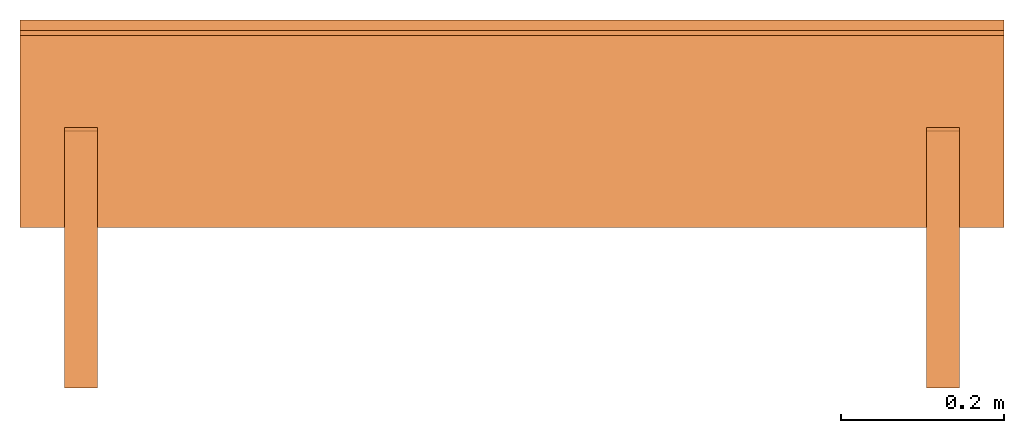
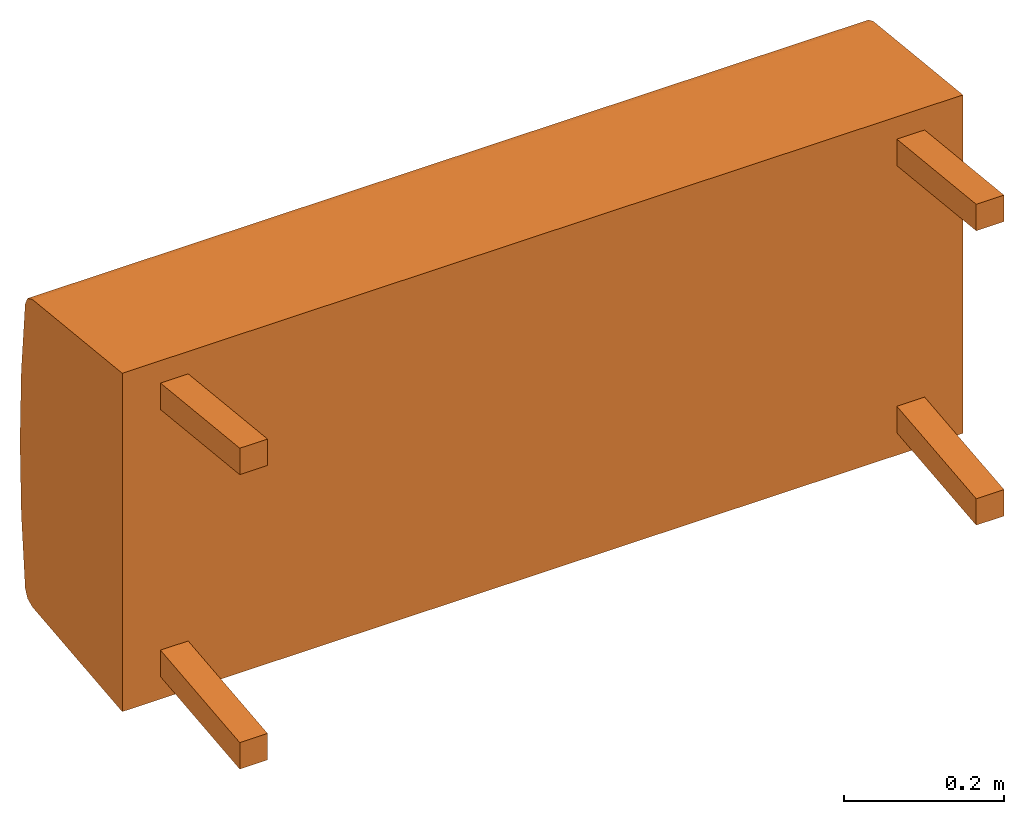
# One storey: 5 proxies, 1 element without a shape of its own.
"""IFC2X3 building model written with IfcOpenShell, lengths in metres."""

from ifc_helpers import new_model, si_unit, direction, origin_with_axes, place, context, project, spatial, faceted_brep, source, transform, mapped, element, aggregate, save


model = new_model("IFC2X3")

# Units and contexts
model_context = context("Model", 3, precision=1e-06, world=origin_with_axes(), true_north=direction((0.0, 1.0, 0.0)))
ifc_project = project(units=[si_unit("LENGTHUNIT", "METRE"), si_unit("AREAUNIT", "SQUARE_METRE"), si_unit("VOLUMEUNIT", "CUBIC_METRE")], contexts=[model_context])

# Site, building, storey
site_placement = place(None, origin_with_axes())
site = spatial("IfcSite", under=ifc_project, at=site_placement, CompositionType="ELEMENT")
building_placement = place(site_placement, origin_with_axes())
building = spatial("IfcBuilding", under=site, at=building_placement, Name="Default Building", CompositionType="ELEMENT")
storey_placement = place(building_placement, origin_with_axes())
storey = spatial("IfcBuildingStorey", under=building, at=storey_placement, Name="Default Storey", CompositionType="ELEMENT", Elevation=0.0)

# Assembly, proxies
assembly_placement = place(storey_placement, origin_with_axes())
assembly = element("IfcElementAssembly", 1, at=assembly_placement, inside=storey, Name="H-04-018-A_2-seater bench", ObjectType="H-04-018-A_2-seater bench", AssemblyPlace="NOTDEFINED", PredefinedType="NOTDEFINED")
shared_shape_1 = source(origin_with_axes(), model_context, "Body", "Brep", [
    faceted_brep([(0.6050000190734863, -0.11101193726062775, -0.2574460208415985), (0.6050000190734863, -0.11100000143051147, 0.25755399465560913), (-0.6050000190734863, -0.11101193726062775, -0.2574460208415985), (-0.6050000190734863, -0.11101193726062775, -0.2574460208415985), (0.6050000190734863, -0.11100000143051147, 0.25755399465560913), (-0.6050000190734863, -0.11100000143051147, 0.25755399465560913), (0.6050000190734863, 0.11315424740314484, -0.23389045894145966), (0.6050000190734863, -0.11101193726062775, -0.2574460208415985), (-0.6050000190734863, 0.11315424740314484, -0.23389045894145966), (-0.6050000190734863, 0.11315424740314484, -0.23389045894145966), (0.6050000190734863, -0.11101193726062775, -0.2574460208415985), (-0.6050000190734863, -0.11101193726062775, -0.2574460208415985), (0.6050000190734863, 0.12509645521640778, -0.22825108468532562), (0.6050000190734863, 0.11315424740314484, -0.23389045894145966), (-0.6050000190734863, 0.12509645521640778, -0.22825108468532562), (-0.6050000190734863, 0.12509645521640778, -0.22825108468532562), (0.6050000190734863, 0.11315424740314484, -0.23389045894145966), (-0.6050000190734863, 0.11315424740314484, -0.23389045894145966), (0.6050000190734863, 0.1309199035167694, -0.21639753878116608), (0.6050000190734863, 0.12509645521640778, -0.22825108468532562), (-0.6050000190734863, 0.1309199035167694, -0.21639753878116608), (-0.6050000190734863, 0.1309199035167694, -0.21639753878116608), (0.6050000190734863, 0.12509645521640778, -0.22825108468532562), (-0.6050000190734863, 0.12509645521640778, -0.22825108468532562), (0.6050000190734863, 0.1406860649585724, -0.10837232321500778), (0.6050000190734863, 0.1309199035167694, -0.21639753878116608), (-0.6050000190734863, 0.1406860649585724, -0.10837232321500778), (-0.6050000190734863, 0.1406860649585724, -0.10837232321500778), (0.6050000190734863, 0.1309199035167694, -0.21639753878116608), (-0.6050000190734863, 0.1309199035167694, -0.21639753878116608), (0.6050000190734863, 0.1439555585384369, 4.417426316649653e-05), (0.6050000190734863, 0.1406860649585724, -0.10837232321500778), (-0.6050000190734863, 0.1439555585384369, 4.417426316649653e-05), (-0.6050000190734863, 0.1439555585384369, 4.417426316649653e-05), (0.6050000190734863, 0.1406860649585724, -0.10837232321500778), (-0.6050000190734863, 0.1406860649585724, -0.10837232321500778), (0.6050000190734863, 0.14071664214134216, 0.10846158862113953), (0.6050000190734863, 0.1439555585384369, 4.417426316649653e-05), (-0.6050000190734863, 0.14071664214134216, 0.10846158862113953), (-0.6050000190734863, 0.14071664214134216, 0.10846158862113953), (0.6050000190734863, 0.1439555585384369, 4.417426316649653e-05), (-0.6050000190734863, 0.1439555585384369, 4.417426316649653e-05), (0.6050000190734863, 0.1309809684753418, 0.21648956835269928), (0.6050000190734863, 0.14071664214134216, 0.10846158862113953), (-0.6050000190734863, 0.1309809684753418, 0.21648956835269928), (-0.6050000190734863, 0.1309809684753418, 0.21648956835269928), (0.6050000190734863, 0.14071664214134216, 0.10846158862113953), (-0.6050000190734863, 0.14071664214134216, 0.10846158862113953), (0.6050000190734863, 0.12515902519226074, 0.2283465564250946), (0.6050000190734863, 0.1309809684753418, 0.21648956835269928), (-0.6050000190734863, 0.12515902519226074, 0.2283465564250946), (-0.6050000190734863, 0.12515902519226074, 0.2283465564250946), (0.6050000190734863, 0.1309809684753418, 0.21648956835269928), (-0.6050000190734863, 0.1309809684753418, 0.21648956835269928), (0.6050000190734863, 0.11321509629487991, 0.23398803174495697), (0.6050000190734863, 0.12515902519226074, 0.2283465564250946), (-0.6050000190734863, 0.11321509629487991, 0.23398803174495697), (-0.6050000190734863, 0.11321509629487991, 0.23398803174495697), (0.6050000190734863, 0.12515902519226074, 0.2283465564250946), (-0.6050000190734863, 0.12515902519226074, 0.2283465564250946), (0.6050000190734863, -0.11100000143051147, 0.25755399465560913), (0.6050000190734863, 0.11321509629487991, 0.23398803174495697), (-0.6050000190734863, -0.11100000143051147, 0.25755399465560913), (-0.6050000190734863, -0.11100000143051147, 0.25755399465560913), (0.6050000190734863, 0.11321509629487991, 0.23398803174495697), (-0.6050000190734863, 0.11321509629487991, 0.23398803174495697), (0.6050000190734863, 0.1309809684753418, 0.21648956835269928), (0.6050000190734863, 0.12515902519226074, 0.2283465564250946), (0.6050000190734863, 0.14071664214134216, 0.10846158862113953), (0.6050000190734863, 0.14071664214134216, 0.10846158862113953), (0.6050000190734863, 0.12515902519226074, 0.2283465564250946), (0.6050000190734863, 0.11321509629487991, 0.23398803174495697), (0.6050000190734863, 0.14071664214134216, 0.10846158862113953), (0.6050000190734863, 0.11321509629487991, 0.23398803174495697), (0.6050000190734863, -0.11100000143051147, 0.25755399465560913), (0.6050000190734863, 0.12509645521640778, -0.22825108468532562), (0.6050000190734863, 0.1309199035167694, -0.21639753878116608), (0.6050000190734863, 0.11315424740314484, -0.23389045894145966), (0.6050000190734863, 0.11315424740314484, -0.23389045894145966), (0.6050000190734863, 0.1309199035167694, -0.21639753878116608), (0.6050000190734863, 0.1406860649585724, -0.10837232321500778), (0.6050000190734863, 0.11315424740314484, -0.23389045894145966), (0.6050000190734863, 0.1406860649585724, -0.10837232321500778), (0.6050000190734863, -0.11101193726062775, -0.2574460208415985), (0.6050000190734863, -0.11101193726062775, -0.2574460208415985), (0.6050000190734863, 0.1406860649585724, -0.10837232321500778), (0.6050000190734863, -0.11100000143051147, 0.25755399465560913), (0.6050000190734863, -0.11100000143051147, 0.25755399465560913), (0.6050000190734863, 0.1406860649585724, -0.10837232321500778), (0.6050000190734863, 0.1439555585384369, 4.417426316649653e-05), (0.6050000190734863, -0.11100000143051147, 0.25755399465560913), (0.6050000190734863, 0.1439555585384369, 4.417426316649653e-05), (0.6050000190734863, 0.14071664214134216, 0.10846158862113953), (-0.6050000190734863, 0.1406860649585724, -0.10837232321500778), (-0.6050000190734863, 0.1309199035167694, -0.21639753878116608), (-0.6050000190734863, 0.12509645521640778, -0.22825108468532562), (-0.6050000190734863, 0.12515902519226074, 0.2283465564250946), (-0.6050000190734863, 0.1309809684753418, 0.21648956835269928), (-0.6050000190734863, 0.11321509629487991, 0.23398803174495697), (-0.6050000190734863, 0.11321509629487991, 0.23398803174495697), (-0.6050000190734863, 0.1309809684753418, 0.21648956835269928), (-0.6050000190734863, 0.14071664214134216, 0.10846158862113953), (-0.6050000190734863, 0.11321509629487991, 0.23398803174495697), (-0.6050000190734863, 0.14071664214134216, 0.10846158862113953), (-0.6050000190734863, -0.11100000143051147, 0.25755399465560913), (-0.6050000190734863, -0.11100000143051147, 0.25755399465560913), (-0.6050000190734863, 0.14071664214134216, 0.10846158862113953), (-0.6050000190734863, 0.1439555585384369, 4.417426316649653e-05), (-0.6050000190734863, -0.11100000143051147, 0.25755399465560913), (-0.6050000190734863, 0.1439555585384369, 4.417426316649653e-05), (-0.6050000190734863, -0.11101193726062775, -0.2574460208415985), (-0.6050000190734863, -0.11101193726062775, -0.2574460208415985), (-0.6050000190734863, 0.1439555585384369, 4.417426316649653e-05), (-0.6050000190734863, 0.1406860649585724, -0.10837232321500778), (-0.6050000190734863, -0.11101193726062775, -0.2574460208415985), (-0.6050000190734863, 0.1406860649585724, -0.10837232321500778), (-0.6050000190734863, 0.11315424740314484, -0.23389045894145966), (-0.6050000190734863, 0.11315424740314484, -0.23389045894145966), (-0.6050000190734863, 0.1406860649585724, -0.10837232321500778), (-0.6050000190734863, 0.12509645521640778, -0.22825108468532562)], [[[0, 1, 2]], [[3, 4, 5]], [[6, 7, 8]], [[9, 10, 11]], [[12, 13, 14]], [[15, 16, 17]], [[18, 19, 20]], [[21, 22, 23]], [[24, 25, 26]], [[27, 28, 29]], [[30, 31, 32]], [[33, 34, 35]], [[36, 37, 38]], [[39, 40, 41]], [[42, 43, 44]], [[45, 46, 47]], [[48, 49, 50]], [[51, 52, 53]], [[54, 55, 56]], [[57, 58, 59]], [[60, 61, 62]], [[63, 64, 65]], [[66, 67, 68]], [[69, 70, 71]], [[72, 73, 74]], [[75, 76, 77]], [[78, 79, 80]], [[81, 82, 83]], [[84, 85, 86]], [[87, 88, 89]], [[90, 91, 92]], [[93, 94, 95]], [[96, 97, 98]], [[99, 100, 101]], [[102, 103, 104]], [[105, 106, 107]], [[108, 109, 110]], [[111, 112, 113]], [[114, 115, 116]], [[117, 118, 119]]]),
])
proxy_1_placement = place(assembly_placement, origin_with_axes())
proxy_1 = element("IfcBuildingElementProxy", 2, at=proxy_1_placement, Name="1", ObjectType="1", CompositionType="ELEMENT", context=model_context, shape_type="MappedRepresentation", body=[
    mapped(shared_shape_1, transform((0.0, 0.0, 0.0), scale=1.0)),
])
shared_shape_2 = source(origin_with_axes(), model_context, "Body", "Brep", [
    faceted_brep([(-0.5099999904632568, -0.3086836636066437, -0.2039259523153305), (-0.5099999904632568, 0.00747277494519949, -0.17069658637046814), (-0.550000011920929, -0.3086836636066437, -0.2039259523153305), (-0.550000011920929, -0.3086836636066437, -0.2039259523153305), (-0.5099999904632568, 0.00747277494519949, -0.17069658637046814), (-0.550000011920929, 0.00747277494519949, -0.17069658637046814), (-0.5099999904632568, -0.3086836636066437, -0.24414628744125366), (-0.5099999904632568, -0.3086836636066437, -0.2039259523153305), (-0.550000011920929, -0.3086836636066437, -0.24414628744125366), (-0.550000011920929, -0.3086836636066437, -0.24414628744125366), (-0.5099999904632568, -0.3086836636066437, -0.2039259523153305), (-0.550000011920929, -0.3086836636066437, -0.2039259523153305), (-0.5099999904632568, 0.011653914116322994, -0.21047745645046234), (-0.5099999904632568, -0.3086836636066437, -0.24414628744125366), (-0.550000011920929, 0.011653914116322994, -0.21047745645046234), (-0.550000011920929, 0.011653914116322994, -0.21047745645046234), (-0.5099999904632568, -0.3086836636066437, -0.24414628744125366), (-0.550000011920929, -0.3086836636066437, -0.24414628744125366), (-0.5099999904632568, 0.00747277494519949, -0.17069658637046814), (-0.5099999904632568, 0.011653914116322994, -0.21047745645046234), (-0.550000011920929, 0.00747277494519949, -0.17069658637046814), (-0.550000011920929, 0.00747277494519949, -0.17069658637046814), (-0.5099999904632568, 0.011653914116322994, -0.21047745645046234), (-0.550000011920929, 0.011653914116322994, -0.21047745645046234), (-0.5099999904632568, -0.3086836636066437, -0.24414628744125366), (-0.5099999904632568, 0.011653914116322994, -0.21047745645046234), (-0.5099999904632568, -0.3086836636066437, -0.2039259523153305), (-0.5099999904632568, -0.3086836636066437, -0.2039259523153305), (-0.5099999904632568, 0.011653914116322994, -0.21047745645046234), (-0.5099999904632568, 0.00747277494519949, -0.17069658637046814), (-0.550000011920929, 0.011653914116322994, -0.21047745645046234), (-0.550000011920929, -0.3086836636066437, -0.24414628744125366), (-0.550000011920929, 0.00747277494519949, -0.17069658637046814), (-0.550000011920929, 0.00747277494519949, -0.17069658637046814), (-0.550000011920929, -0.3086836636066437, -0.24414628744125366), (-0.550000011920929, -0.3086836636066437, -0.2039259523153305)], [[[0, 1, 2]], [[3, 4, 5]], [[6, 7, 8]], [[9, 10, 11]], [[12, 13, 14]], [[15, 16, 17]], [[18, 19, 20]], [[21, 22, 23]], [[24, 25, 26]], [[27, 28, 29]], [[30, 31, 32]], [[33, 34, 35]]]),
])
proxy_2_placement = place(assembly_placement, origin_with_axes())
proxy_2 = element("IfcBuildingElementProxy", 3, at=proxy_2_placement, Name="2", ObjectType="2", CompositionType="ELEMENT", context=model_context, shape_type="MappedRepresentation", body=[
    mapped(shared_shape_2, transform((0.0, 0.0, 0.0), scale=1.0)),
])
shared_shape_3 = source(origin_with_axes(), model_context, "Body", "Brep", [
    faceted_brep([(-0.5099999904632568, -0.3086836636066437, 0.203923761844635), (-0.5099999904632568, -0.3086836636066437, 0.24414409697055817), (-0.550000011920929, -0.3086836636066437, 0.203923761844635), (-0.550000011920929, -0.3086836636066437, 0.203923761844635), (-0.5099999904632568, -0.3086836636066437, 0.24414409697055817), (-0.550000011920929, -0.3086836636066437, 0.24414409697055817), (-0.5099999904632568, 0.00747277494519949, 0.17069438099861145), (-0.5099999904632568, -0.3086836636066437, 0.203923761844635), (-0.550000011920929, 0.00747277494519949, 0.17069438099861145), (-0.550000011920929, 0.00747277494519949, 0.17069438099861145), (-0.5099999904632568, -0.3086836636066437, 0.203923761844635), (-0.550000011920929, -0.3086836636066437, 0.203923761844635), (-0.5099999904632568, 0.011653914116322994, 0.21047525107860565), (-0.5099999904632568, 0.00747277494519949, 0.17069438099861145), (-0.550000011920929, 0.011653914116322994, 0.21047525107860565), (-0.550000011920929, 0.011653914116322994, 0.21047525107860565), (-0.5099999904632568, 0.00747277494519949, 0.17069438099861145), (-0.550000011920929, 0.00747277494519949, 0.17069438099861145), (-0.5099999904632568, -0.3086836636066437, 0.24414409697055817), (-0.5099999904632568, 0.011653914116322994, 0.21047525107860565), (-0.550000011920929, -0.3086836636066437, 0.24414409697055817), (-0.550000011920929, -0.3086836636066437, 0.24414409697055817), (-0.5099999904632568, 0.011653914116322994, 0.21047525107860565), (-0.550000011920929, 0.011653914116322994, 0.21047525107860565), (-0.5099999904632568, 0.00747277494519949, 0.17069438099861145), (-0.5099999904632568, 0.011653914116322994, 0.21047525107860565), (-0.5099999904632568, -0.3086836636066437, 0.203923761844635), (-0.5099999904632568, -0.3086836636066437, 0.203923761844635), (-0.5099999904632568, 0.011653914116322994, 0.21047525107860565), (-0.5099999904632568, -0.3086836636066437, 0.24414409697055817), (-0.550000011920929, 0.011653914116322994, 0.21047525107860565), (-0.550000011920929, 0.00747277494519949, 0.17069438099861145), (-0.550000011920929, -0.3086836636066437, 0.24414409697055817), (-0.550000011920929, -0.3086836636066437, 0.24414409697055817), (-0.550000011920929, 0.00747277494519949, 0.17069438099861145), (-0.550000011920929, -0.3086836636066437, 0.203923761844635)], [[[0, 1, 2]], [[3, 4, 5]], [[6, 7, 8]], [[9, 10, 11]], [[12, 13, 14]], [[15, 16, 17]], [[18, 19, 20]], [[21, 22, 23]], [[24, 25, 26]], [[27, 28, 29]], [[30, 31, 32]], [[33, 34, 35]]]),
])
proxy_3_placement = place(assembly_placement, origin_with_axes())
proxy_3 = element("IfcBuildingElementProxy", 4, at=proxy_3_placement, Name="3", ObjectType="3", CompositionType="ELEMENT", context=model_context, shape_type="MappedRepresentation", body=[
    mapped(shared_shape_3, transform((0.0, 0.0, 0.0), scale=1.0)),
])
shared_shape_4 = source(origin_with_axes(), model_context, "Body", "Brep", [
    faceted_brep([(0.550000011920929, -0.3086836636066437, 0.203923761844635), (0.550000011920929, -0.3086836636066437, 0.24414409697055817), (0.5099999904632568, -0.3086836636066437, 0.203923761844635), (0.5099999904632568, -0.3086836636066437, 0.203923761844635), (0.550000011920929, -0.3086836636066437, 0.24414409697055817), (0.5099999904632568, -0.3086836636066437, 0.24414409697055817), (0.550000011920929, 0.00747277494519949, 0.17069438099861145), (0.550000011920929, -0.3086836636066437, 0.203923761844635), (0.5099999904632568, 0.00747277494519949, 0.17069438099861145), (0.5099999904632568, 0.00747277494519949, 0.17069438099861145), (0.550000011920929, -0.3086836636066437, 0.203923761844635), (0.5099999904632568, -0.3086836636066437, 0.203923761844635), (0.550000011920929, 0.011653914116322994, 0.21047525107860565), (0.550000011920929, 0.00747277494519949, 0.17069438099861145), (0.5099999904632568, 0.011653914116322994, 0.21047525107860565), (0.5099999904632568, 0.011653914116322994, 0.21047525107860565), (0.550000011920929, 0.00747277494519949, 0.17069438099861145), (0.5099999904632568, 0.00747277494519949, 0.17069438099861145), (0.550000011920929, -0.3086836636066437, 0.24414409697055817), (0.550000011920929, 0.011653914116322994, 0.21047525107860565), (0.5099999904632568, -0.3086836636066437, 0.24414409697055817), (0.5099999904632568, -0.3086836636066437, 0.24414409697055817), (0.550000011920929, 0.011653914116322994, 0.21047525107860565), (0.5099999904632568, 0.011653914116322994, 0.21047525107860565), (0.550000011920929, 0.00747277494519949, 0.17069438099861145), (0.550000011920929, 0.011653914116322994, 0.21047525107860565), (0.550000011920929, -0.3086836636066437, 0.203923761844635), (0.550000011920929, -0.3086836636066437, 0.203923761844635), (0.550000011920929, 0.011653914116322994, 0.21047525107860565), (0.550000011920929, -0.3086836636066437, 0.24414409697055817), (0.5099999904632568, 0.011653914116322994, 0.21047525107860565), (0.5099999904632568, 0.00747277494519949, 0.17069438099861145), (0.5099999904632568, -0.3086836636066437, 0.24414409697055817), (0.5099999904632568, -0.3086836636066437, 0.24414409697055817), (0.5099999904632568, 0.00747277494519949, 0.17069438099861145), (0.5099999904632568, -0.3086836636066437, 0.203923761844635)], [[[0, 1, 2]], [[3, 4, 5]], [[6, 7, 8]], [[9, 10, 11]], [[12, 13, 14]], [[15, 16, 17]], [[18, 19, 20]], [[21, 22, 23]], [[24, 25, 26]], [[27, 28, 29]], [[30, 31, 32]], [[33, 34, 35]]]),
])
proxy_4_placement = place(assembly_placement, origin_with_axes())
proxy_4 = element("IfcBuildingElementProxy", 5, at=proxy_4_placement, Name="4", ObjectType="4", CompositionType="ELEMENT", context=model_context, shape_type="MappedRepresentation", body=[
    mapped(shared_shape_4, transform((0.0, 0.0, 0.0), scale=1.0)),
])
shared_shape_5 = source(origin_with_axes(), model_context, "Body", "Brep", [
    faceted_brep([(0.550000011920929, -0.3086836636066437, -0.2039259523153305), (0.550000011920929, 0.00747277494519949, -0.17069658637046814), (0.5099999904632568, -0.3086836636066437, -0.2039259523153305), (0.5099999904632568, -0.3086836636066437, -0.2039259523153305), (0.550000011920929, 0.00747277494519949, -0.17069658637046814), (0.5099999904632568, 0.00747277494519949, -0.17069658637046814), (0.550000011920929, -0.3086836636066437, -0.24414628744125366), (0.550000011920929, -0.3086836636066437, -0.2039259523153305), (0.5099999904632568, -0.3086836636066437, -0.24414628744125366), (0.5099999904632568, -0.3086836636066437, -0.24414628744125366), (0.550000011920929, -0.3086836636066437, -0.2039259523153305), (0.5099999904632568, -0.3086836636066437, -0.2039259523153305), (0.550000011920929, 0.011653914116322994, -0.21047745645046234), (0.550000011920929, -0.3086836636066437, -0.24414628744125366), (0.5099999904632568, 0.011653914116322994, -0.21047745645046234), (0.5099999904632568, 0.011653914116322994, -0.21047745645046234), (0.550000011920929, -0.3086836636066437, -0.24414628744125366), (0.5099999904632568, -0.3086836636066437, -0.24414628744125366), (0.550000011920929, 0.00747277494519949, -0.17069658637046814), (0.550000011920929, 0.011653914116322994, -0.21047745645046234), (0.5099999904632568, 0.00747277494519949, -0.17069658637046814), (0.5099999904632568, 0.00747277494519949, -0.17069658637046814), (0.550000011920929, 0.011653914116322994, -0.21047745645046234), (0.5099999904632568, 0.011653914116322994, -0.21047745645046234), (0.550000011920929, -0.3086836636066437, -0.24414628744125366), (0.550000011920929, 0.011653914116322994, -0.21047745645046234), (0.550000011920929, -0.3086836636066437, -0.2039259523153305), (0.550000011920929, -0.3086836636066437, -0.2039259523153305), (0.550000011920929, 0.011653914116322994, -0.21047745645046234), (0.550000011920929, 0.00747277494519949, -0.17069658637046814), (0.5099999904632568, 0.011653914116322994, -0.21047745645046234), (0.5099999904632568, -0.3086836636066437, -0.24414628744125366), (0.5099999904632568, 0.00747277494519949, -0.17069658637046814), (0.5099999904632568, 0.00747277494519949, -0.17069658637046814), (0.5099999904632568, -0.3086836636066437, -0.24414628744125366), (0.5099999904632568, -0.3086836636066437, -0.2039259523153305)], [[[0, 1, 2]], [[3, 4, 5]], [[6, 7, 8]], [[9, 10, 11]], [[12, 13, 14]], [[15, 16, 17]], [[18, 19, 20]], [[21, 22, 23]], [[24, 25, 26]], [[27, 28, 29]], [[30, 31, 32]], [[33, 34, 35]]]),
])
proxy_5_placement = place(assembly_placement, origin_with_axes())
proxy_5 = element("IfcBuildingElementProxy", 6, at=proxy_5_placement, Name="5", ObjectType="5", CompositionType="ELEMENT", context=model_context, shape_type="MappedRepresentation", body=[
    mapped(shared_shape_5, transform((0.0, 0.0, 0.0), scale=1.0)),
])
aggregate(assembly, [proxy_1, proxy_2, proxy_3, proxy_4, proxy_5])

save(model, "model.ifc")
